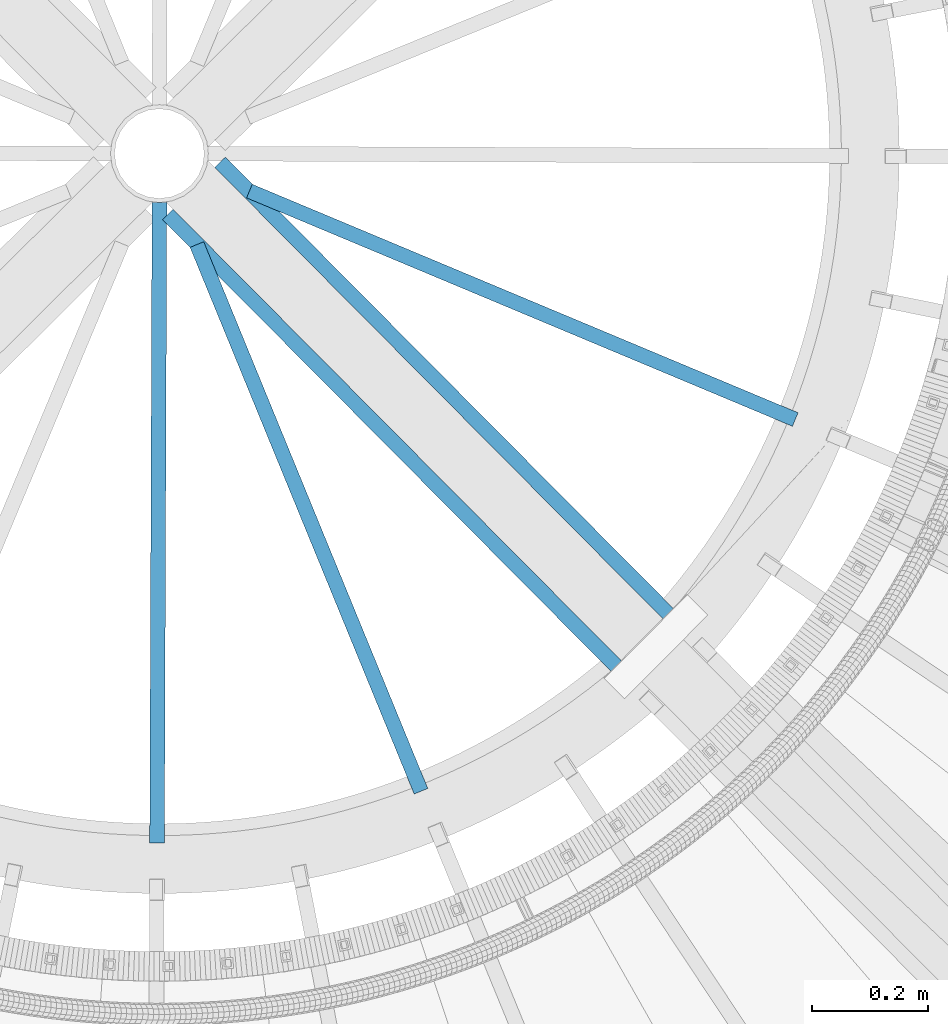
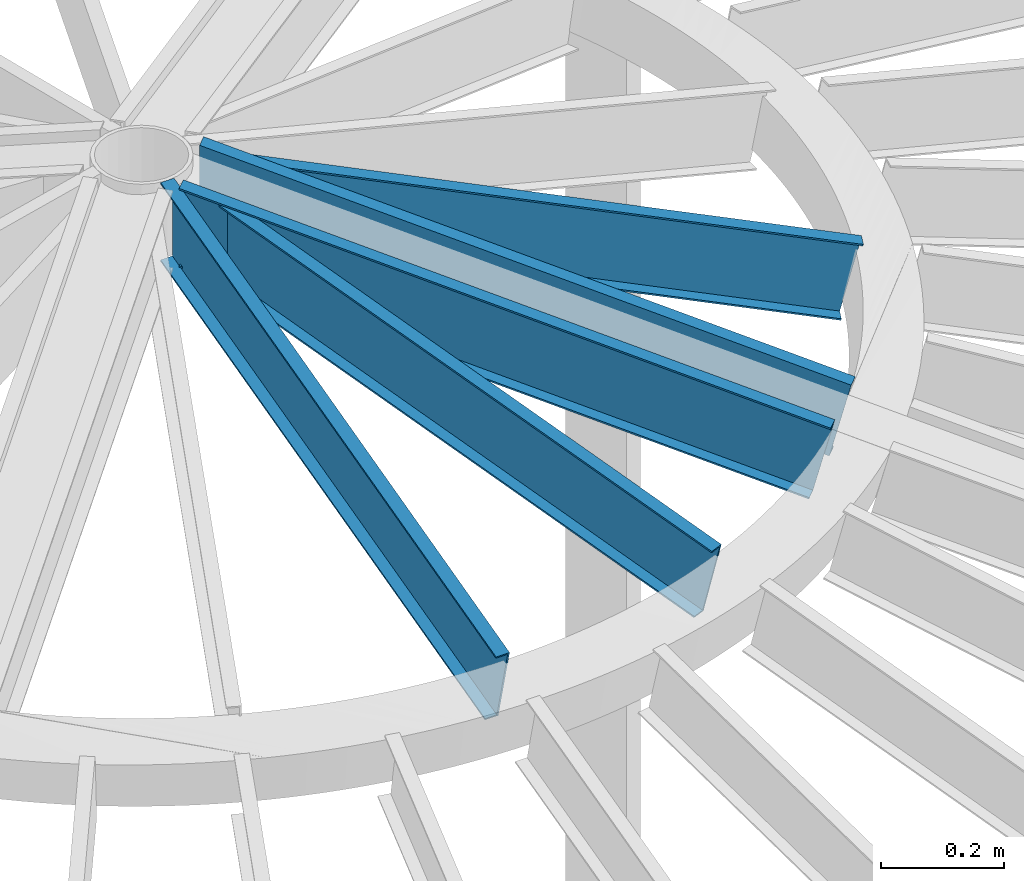
# One storey, part 348 of 975: 5 beams.
"""IFC2X3 building model written with IfcOpenShell, lengths in millimetres."""

from ifc_helpers import new_model, si_unit, frame, origin_with_axes, place, context, subcontext, project, spatial, faceted_brep, material, type_object, element, save


model = new_model("IFC2X3")

# Units and contexts
model_context = context("Model", 3, precision=1e-05, world=origin_with_axes())
body_context = subcontext(model_context, "Body", "Model", "MODEL_VIEW")
ifc_project = project(units=[si_unit("LENGTHUNIT", "METRE", prefix="MILLI"), si_unit("AREAUNIT", "SQUARE_METRE"), si_unit("VOLUMEUNIT", "CUBIC_METRE"), si_unit("MASSUNIT", "GRAM", prefix="KILO"), si_unit("TIMEUNIT", "SECOND"), si_unit("PLANEANGLEUNIT", "RADIAN"), si_unit("SOLIDANGLEUNIT", "STERADIAN"), si_unit("THERMODYNAMICTEMPERATUREUNIT", "DEGREE_CELSIUS"), si_unit("LUMINOUSINTENSITYUNIT", "LUMEN")], contexts=[model_context])

# Site, building, storey
site_placement = place(None, origin_with_axes())
site = spatial("IfcSite", under=ifc_project, at=site_placement, CompositionType="ELEMENT")
building_placement = place(site_placement, origin_with_axes())
building = spatial("IfcBuilding", under=site, at=building_placement, Name="Undefined", CompositionType="ELEMENT")
storey_placement = place(building_placement, origin_with_axes())
storey = spatial("IfcBuildingStorey", under=building, at=storey_placement, Name="Undefined", CompositionType="ELEMENT", Elevation=0.0)

# Beams
ifc_material = material(Name="STEEL/Zero_Density")
beam_type = type_object("IfcBeamType", PredefinedType="NOTDEFINED")
beam_1_placement = place(storey_placement, frame((34759.6765838542, 3343.09671254987, 9185.06096723024), z_axis=(0.091995151989293, -0.224418098973873, 0.970140922167197), x_axis=(0.367970434790038, -0.897647574487811, -0.242541936861608)))
element("IfcBeam", 1, at=beam_1_placement, inside=storey, type_object=beam_type, material=ifc_material, Name="STUD", context=body_context, shape_type="Brep", body=[
    faceted_brep([(1134.70057945789, -12.6999999990348, 76.200000000108), (1134.70057945789, -12.6999999990367, 73.0250000001097), (1134.70057945792, 9.52500000095824, 73.025000000097), (1134.70057945806, 9.52500000092914, -73.0249999998405), (1134.70057945804, -12.6999999990658, -73.0249999998296), (1134.70057945805, -12.6999999990658, -76.1999999998279), (1134.70057945806, 12.7000000009302, -76.1999999998443), (1134.70057945791, 12.700000000963, 76.2000000000953), (125.830470330438, -12.699999999908, -76.199999999948), (125.830470360648, 12.700000000088, -76.1999999999616), (87.7294169224115, 12.7000000000862, 76.1999999999744), (87.7294168921944, -12.699999999908, 76.1999999999871), (88.5231888388298, -12.6999999999098, 73.0249999999878), (88.5231888652634, 9.52500000008513, 73.024999999976), (125.036698410244, 9.52500000008877, -73.0249999999596), (125.03669838381, -12.6999999999061, -73.0249999999487)], [[[0, 1, 2, 3, 4, 5, 6, 7]], [[6, 5, 8, 9]], [[7, 6, 9, 10]], [[0, 7, 10, 11]], [[1, 0, 11, 12]], [[2, 1, 12, 13]], [[3, 2, 13, 14]], [[4, 3, 14, 15]], [[5, 4, 15, 8]], [[14, 13, 12, 11, 10, 9, 8, 15]]]),
])
beam_2_placement = place(storey_placement, frame((34795.0848180105, 3378.62024833033, 9185.06096723024), z_axis=(0.223737955733079, -0.0936371633068038, 0.970140922140819), x_axis=(0.894927076878677, -0.374538296949224, -0.242541936967119)))
element("IfcBeam", 2, at=beam_2_placement, inside=storey, type_object=beam_type, material=ifc_material, Name="STUD", context=body_context, shape_type="Brep", body=[
    faceted_brep([(1134.70057945789, -12.6999999990348, 76.200000000108), (1134.70057945789, -12.6999999990367, 73.0250000001097), (1134.70057945792, 9.52500000095824, 73.025000000097), (1134.70057945806, 9.52500000092914, -73.0249999998405), (1134.70057945804, -12.6999999990658, -73.0249999998296), (1134.70057945805, -12.6999999990658, -76.1999999998279), (1134.70057945806, 12.7000000009302, -76.1999999998443), (1134.70057945791, 12.700000000963, 76.2000000000953), (124.283917888468, -12.7000000001171, -76.1999999999734), (124.283917926634, 12.6999999999316, -76.1999999999898), (86.1828643469635, 12.6999999999425, 76.200000000108), (86.1828643088047, -12.7000000001062, 76.2000000001244), (86.9766362583796, -12.7000000001099, 73.0250000001215), (86.9766362917726, 9.52499999993961, 73.0250000001079), (123.490145972286, 9.52499999993233, -73.0249999999851), (123.490145938893, -12.7000000001171, -73.0249999999724)], [[[0, 1, 2, 3, 4, 5, 6, 7]], [[6, 5, 8, 9]], [[7, 6, 9, 10]], [[0, 7, 10, 11]], [[1, 0, 11, 12]], [[2, 1, 12, 13]], [[3, 2, 13, 14]], [[4, 3, 14, 15]], [[5, 4, 15, 8]], [[14, 13, 12, 11, 10, 9, 8, 15]]]),
])
for number, where, z_axis, x_axis, name in (
    (3, (34734.6065248106, 3338.06758955063, 9185.06096723024), (-0.000888649999629706, -0.242540308898345, 0.970140922165782), (-0.00355450199805182, -0.970134410469095, -0.24254193686727), "STUD"),
    (4, (34735.7811770473, 3312.27015320504, 9185.06096723024), (0.170873527176511, -0.172130267177808, 0.970140922150774), (0.683475207795134, -0.688502032793624, -0.242541936927299), "STUD"),
):
    element("IfcBeam", number, at=place(storey_placement, frame(where, z_axis=z_axis, x_axis=x_axis)), inside=storey, type_object=beam_type, material=ifc_material, Name=name, context=body_context, shape_type="Brep", body=[
        faceted_brep([(1134.70057945789, -12.6999999990348, 76.200000000108), (1134.70057945789, -12.6999999990367, 73.0250000001097), (1134.70057945792, 9.52500000095824, 73.025000000097), (1134.70057945806, 9.52500000092914, -73.0249999998405), (1134.70057945804, -12.6999999990658, -73.0249999998296), (1134.70057945805, -12.6999999990658, -76.1999999998279), (1134.70057945806, 12.7000000009302, -76.1999999998443), (1134.70057945791, 12.700000000963, 76.2000000000953), (38.1010538948394, -12.7000000000157, -76.1999999999643), (38.1010539016352, 12.6999999999862, -76.1999999999662), (1.96450855582952e-10, 12.7000000001644, 76.2000000001021), (1.74622982740402e-10, -12.6999999998661, 76.2000000000985), (0.79377234254207, -12.699999999993, 73.0249999999905), (0.793772348486527, 9.52500000000873, 73.0249999999905), (37.3072819528606, 9.52499999998645, -73.0249999999669), (37.3072819469235, -12.7000000000148, -73.0249999999651)], [[[0, 1, 2, 3, 4, 5, 6, 7]], [[6, 5, 8, 9]], [[7, 6, 9, 10]], [[0, 7, 10, 11]], [[1, 0, 11, 12]], [[2, 1, 12, 13]], [[3, 2, 13, 14]], [[4, 3, 14, 15]], [[5, 4, 15, 8]], [[14, 13, 12, 11, 10, 9, 8, 15]]]),
    ])
beam_3_placement = place(storey_placement, frame((35601.4047069166, 2620.45259125926, 8909.8484911832), z_axis=(0.170873527176511, -0.172130267177808, 0.970140922150774), x_axis=(-0.683475126987411, 0.688502112987316, 0.242541936995532)))
element("IfcBeam", 5, at=beam_3_placement, inside=storey, type_object=beam_type, material=ifc_material, Name="STUD", context=body_context, shape_type="Brep", body=[
    faceted_brep([(-1.92812876775861e-10, -12.7000000001717, -76.2000000001003), (-1.81898940354586e-10, -12.7000000001608, -73.0250000000965), (-1.60071067512035e-10, 9.52499999986321, -73.0250000000938), (1.89174897968769e-10, 9.52500000015425, 73.0250000000974), (1.67347025126219e-10, -12.6999999998698, 73.0250000000947), (1.74622982740402e-10, -12.6999999998661, 76.2000000000985), (1.96450855582952e-10, 12.7000000001644, 76.2000000001021), (-1.67347025126219e-10, 12.6999999998588, -76.2000000000985), (1134.70057945789, -12.6999999990348, 76.200000000108), (1134.70057945791, 12.700000000963, 76.2000000000953), (1096.59952564954, 12.6999999982763, -76.1999999995651), (1096.59952565276, -12.7000000017433, -76.1999999995523), (1097.39329760113, -12.700000001747, -73.0249999995513), (1097.39329759832, 9.52499999827342, -73.0249999995613), (1133.90680722362, 9.5249999982334, 73.0250000005217), (1133.90680722643, -12.7000000017833, 73.0250000005308)], [[[0, 1, 2, 3, 4, 5, 6, 7]], [[8, 9, 6, 5]], [[7, 6, 9, 10]], [[0, 7, 10, 11]], [[1, 0, 11, 12]], [[2, 1, 12, 13]], [[3, 2, 13, 14]], [[4, 3, 14, 15]], [[5, 4, 15, 8]], [[14, 13, 12, 11, 10, 9, 8, 15]]]),
])

save(model, "model.ifc")
